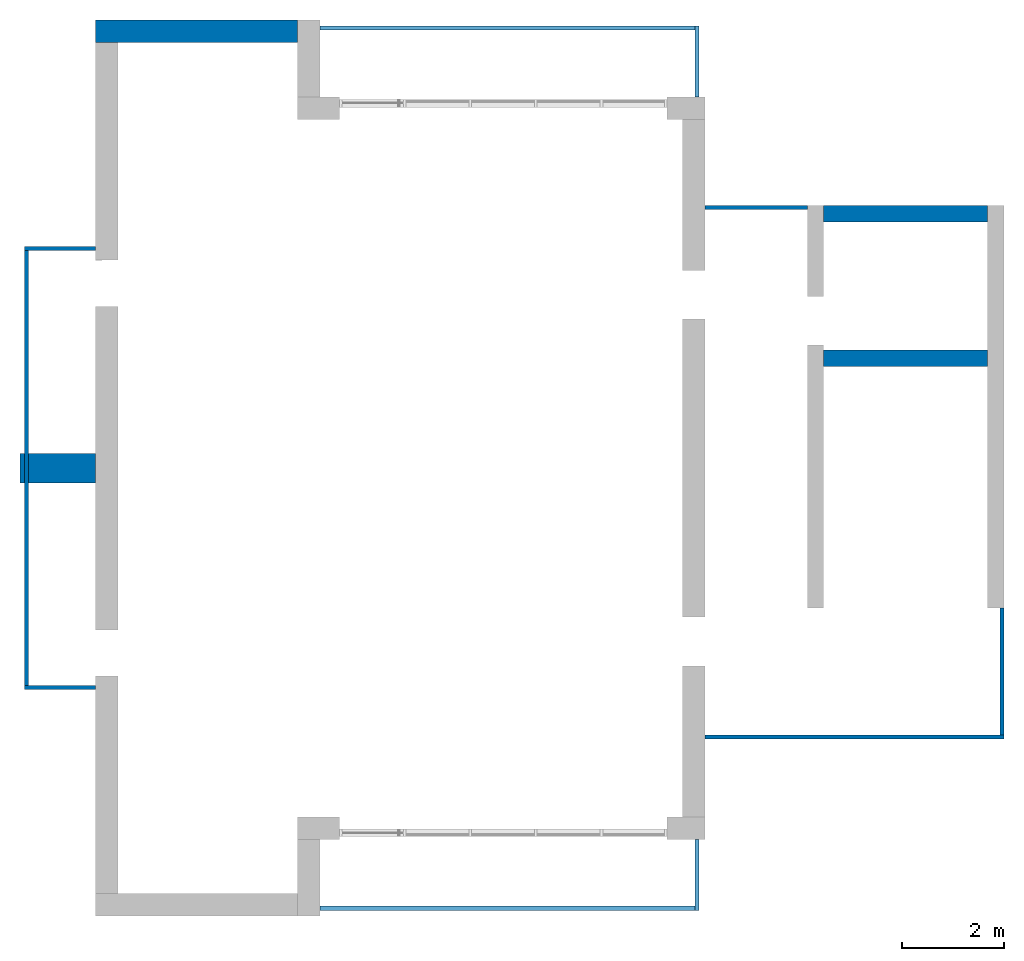
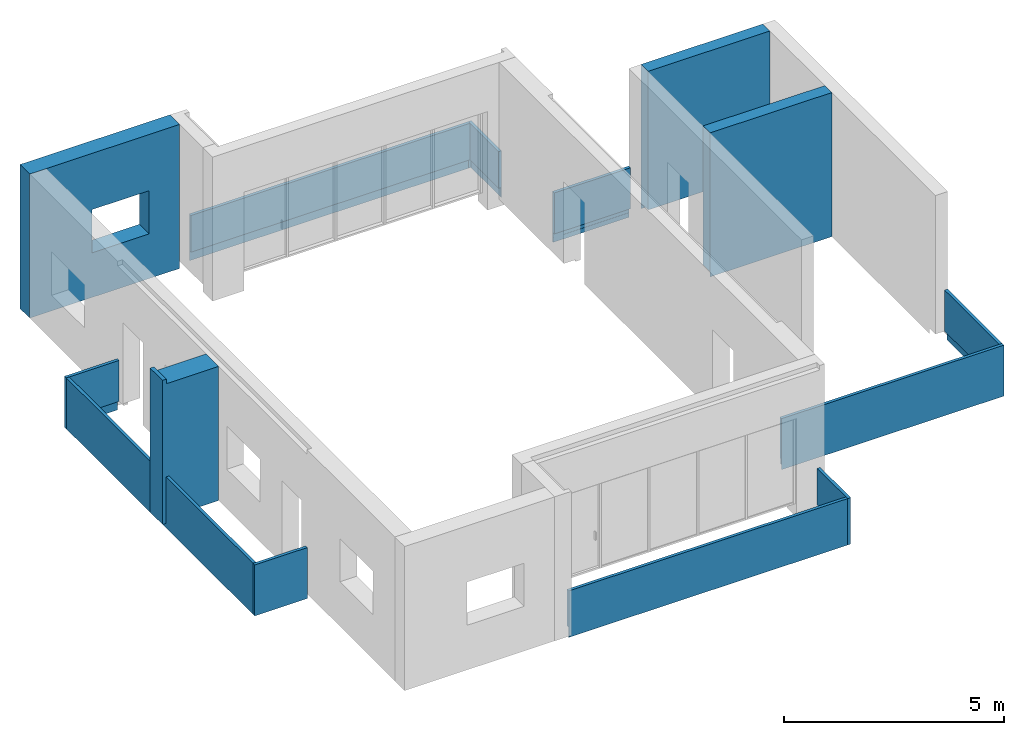
# One storey, part 2 of 4: 14 walls, 1 opening.
"""IFC2X3 building model written with IfcOpenShell, lengths in millimetres."""

from ifc_helpers import new_model, entity, si_unit, converted_unit, derived_unit, direction, frame, frame_2d, origin, place, context, subcontext, project, spatial, polyline, rectangle, extrude, clip, bounded_halfspace, faceted_brep, material, layer, layer_set, layer_usage, type_object, element, save


model = new_model("IFC2X3")

# Units and contexts
model_context = context("Model", 3, precision=0.01, world=origin(), true_north=direction((6.12303176911189e-17, 1.0)))
body_context = subcontext(model_context, "Body", "Model", "MODEL_VIEW")
ifc_project = project(units=[si_unit("LENGTHUNIT", "METRE", prefix="MILLI"), si_unit("AREAUNIT", "SQUARE_METRE"), si_unit("VOLUMEUNIT", "CUBIC_METRE"), converted_unit("PLANEANGLEUNIT", "DEGREE", entity("IfcRatioMeasure", 0.0174532925199433), si_unit("PLANEANGLEUNIT", "RADIAN"), dimensions=[0, 0, 0, 0, 0, 0, 0]), si_unit("MASSUNIT", "GRAM", prefix="KILO"), derived_unit("MASSDENSITYUNIT", [(si_unit("MASSUNIT", "GRAM", prefix="KILO"), 1), (si_unit("LENGTHUNIT", "METRE"), -3)]), si_unit("TIMEUNIT", "SECOND"), si_unit("FREQUENCYUNIT", "HERTZ"), si_unit("THERMODYNAMICTEMPERATUREUNIT", "DEGREE_CELSIUS"), derived_unit("THERMALTRANSMITTANCEUNIT", [(si_unit("MASSUNIT", "GRAM", prefix="KILO"), 1), (si_unit("THERMODYNAMICTEMPERATUREUNIT", "KELVIN"), -1), (si_unit("TIMEUNIT", "SECOND"), -3)]), derived_unit("VOLUMETRICFLOWRATEUNIT", [(si_unit("LENGTHUNIT", "METRE"), 3), (si_unit("TIMEUNIT", "SECOND"), -1)]), si_unit("ELECTRICCURRENTUNIT", "AMPERE"), si_unit("ELECTRICVOLTAGEUNIT", "VOLT"), si_unit("POWERUNIT", "WATT"), si_unit("FORCEUNIT", "NEWTON", prefix="KILO"), si_unit("ILLUMINANCEUNIT", "LUX"), si_unit("LUMINOUSFLUXUNIT", "LUMEN"), si_unit("LUMINOUSINTENSITYUNIT", "CANDELA"), derived_unit("USERDEFINED", [(si_unit("MASSUNIT", "GRAM", prefix="KILO"), -1), (si_unit("LENGTHUNIT", "METRE"), -2), (si_unit("TIMEUNIT", "SECOND"), 3), (si_unit("LUMINOUSFLUXUNIT", "LUMEN"), 1)]), derived_unit("LINEARVELOCITYUNIT", [(si_unit("LENGTHUNIT", "METRE"), 1), (si_unit("TIMEUNIT", "SECOND"), -1)]), si_unit("PRESSUREUNIT", "PASCAL"), derived_unit("USERDEFINED", [(si_unit("LENGTHUNIT", "METRE"), -2), (si_unit("MASSUNIT", "GRAM", prefix="KILO"), 1), (si_unit("TIMEUNIT", "SECOND"), -2)])], contexts=[model_context])

# Site, building, storey
site_placement = place(None, origin())
site = spatial("IfcSite", under=ifc_project, at=site_placement, CompositionType="ELEMENT")
building_placement = place(site_placement, origin())
building = spatial("IfcBuilding", under=site, at=building_placement, CompositionType="ELEMENT")
storey_placement = place(building_placement, frame((0.0, 0.0, 8000.0)))
storey = spatial("IfcBuildingStorey", under=building, at=storey_placement, Name="02 Level", CompositionType="ELEMENT", Elevation=8000.0)

# Wall, opening
ifc_material_1 = material(Name="03")
ifc_layer_1 = layer(ifc_material_1, 10.0)
ifc_material_2 = material()
ifc_layer_2 = layer(ifc_material_2, 120.0)
ifc_material_3 = material()
ifc_layer_3 = layer(ifc_material_3, 300.0)
ifc_layer_4 = layer(ifc_material_1, 10.0)
ifc_layer_set_1 = layer_set([ifc_layer_1, ifc_layer_2, ifc_layer_3, ifc_layer_4], Name="Basic Wall:00_fal+12 cm")
ifc_layer_usage_1 = layer_usage(ifc_layer_set_1, "AXIS2", "POSITIVE", -220.0)
wall_type_1 = type_object("IfcWallType", Name="Basic Wall:00_fal+12 cm", PredefinedType="STANDARD", material=ifc_layer_set_1)
wall_1_placement = place(storey_placement, frame((20983.4900708518, -60301.2395851399, -340.0), z_axis=(0.0, 0.0, 1.0), x_axis=(-1.0, 0.0, 0.0)))
wall_1 = element("IfcWallStandardCase", 1, at=wall_1_placement, inside=storey, type_object=wall_type_1, material=ifc_layer_usage_1, Name="Basic Wall:00_fal+12 cm", ObjectType="Basic Wall:00_fal+12 cm", context=body_context, shape_type="SweptSolid", body=[
    extrude(rectangle(XDim=3940.00000000004, YDim=440.000000000004, at=frame_2d((1970.00000000002, -1.08002495835535e-12), x_axis=(-1.0, 0.0))), origin(), (0.0, 0.0, 1.0), 4000.0),
])
opening_placement = place(wall_1_placement, frame((2300.0, 1304.0, 1240.0), z_axis=(0.0, 0.0, 1.0), x_axis=(-1.0, 0.0, 0.0)))
element("IfcOpeningElement", 2, at=opening_placement, cuts=wall_1, Name="Basic Wall:00_fal+12 cm", ObjectType="Opening", context=body_context, shape_type="SweptSolid", body=[
    extrude(rectangle(XDim=1200.0, YDim=1500.0, at=frame_2d((1.08002495835535e-12, 5.11590769747272e-13), x_axis=(0.0, 1.0))), frame((750.0, 3048.0, 600.0), z_axis=(0.0, -1.0, 0.0), x_axis=(1.0, 0.0, 0.0)), (0.0, 0.0, 1.0), 3048.0),
])

# Walls
ifc_layer_5 = layer(ifc_material_1, 10.0)
ifc_layer_6 = layer(ifc_material_3, 300.0)
ifc_layer_7 = layer(ifc_material_1, 10.0)
ifc_layer_set_2 = layer_set([ifc_layer_5, ifc_layer_6, ifc_layer_7], Name="Basic Wall:00_fal 300 mm")
ifc_layer_usage_2 = layer_usage(ifc_layer_set_2, "AXIS2", "NEGATIVE", 160.0)
wall_type_2 = type_object("IfcWallType", Name="Basic Wall:00_fal 300 mm", PredefinedType="STANDARD", material=ifc_layer_set_2)
wall_2_placement = place(storey_placement, frame((31263.4900708518, -66685.8241905964, -340.0)))
element("IfcWallStandardCase", 3, at=wall_2_placement, inside=storey, type_object=wall_type_2, material=ifc_layer_usage_2, Name="Basic Wall:00_fal 300 mm", ObjectType="Basic Wall:00_fal 300 mm", context=body_context, shape_type="Clipping", body=[
    clip(clip(extrude(rectangle(XDim=3199.99999999998, YDim=319.999999999997, at=frame_2d((1599.99999999999, 1.406874616805e-12), x_axis=(-1.0, 0.0))), origin(), (0.0, 0.0, 1.0), 4000.0), bounded_halfspace(frame((3200.0, -150.0, 150.0), z_axis=(0.0, 0.0, 1.0), x_axis=(0.0, 1.0, 0.0)), True, frame((3200.0, -150.0, 150.0), z_axis=(0.0, 0.0, 1.0), x_axis=(0.0, 1.0, 0.0)), polyline([(0.0, 0.0), (310.0, 0.0), (310.0, 3200.0), (0.0, 3200.0), (0.0, 0.0)]))), bounded_halfspace(frame((0.0, -150.0, 150.0), z_axis=(0.0, -1.0, 0.0), x_axis=(0.0, 0.0, 1.0)), True, frame((0.0, -150.0, 150.0), z_axis=(0.0, -1.0, 0.0), x_axis=(0.0, 0.0, 1.0)), polyline([(0.0, 0.0), (-150.0, 0.0), (-150.0, -3200.0), (0.0, -3200.0), (0.0, 0.0)]))),
])
ifc_layer_usage_3 = layer_usage(ifc_layer_set_2, "AXIS2", "NEGATIVE", 160.0)
wall_3_placement = place(storey_placement, frame((31263.4900708518, -63865.8241905964, -340.0)))
element("IfcWallStandardCase", 4, at=wall_3_placement, inside=storey, type_object=wall_type_2, material=ifc_layer_usage_3, Name="Basic Wall:00_fal 300 mm", ObjectType="Basic Wall:00_fal 300 mm", context=body_context, shape_type="Clipping", body=[
    clip(clip(extrude(rectangle(XDim=3199.99999999998, YDim=319.999999999997, at=frame_2d((1599.99999999999, 0.0), x_axis=(-1.0, 0.0))), origin(), (0.0, 0.0, 1.0), 4000.0), bounded_halfspace(frame((0.0, 150.0, 150.0), z_axis=(0.0, 0.0, 1.0), x_axis=(0.0, 1.0, 0.0)), True, frame((0.0, 150.0, 150.0), z_axis=(0.0, 0.0, 1.0), x_axis=(0.0, 1.0, 0.0)), polyline([(0.0, 0.0), (-310.0, 0.0), (-310.0, -3200.0), (0.0, -3200.0), (0.0, 0.0)]))), bounded_halfspace(frame((3200.0, 150.0, 150.0), z_axis=(0.0, 1.0, 0.0), x_axis=(0.0, 0.0, 1.0)), True, frame((3200.0, 150.0, 150.0), z_axis=(0.0, 1.0, 0.0), x_axis=(0.0, 0.0, 1.0)), polyline([(0.0, 0.0), (-150.0, 0.0), (-150.0, -3200.0), (0.0, -3200.0), (0.0, 0.0)]))),
])
ifc_layer_8 = layer(ifc_material_1, 10.0)
ifc_material_4 = material(Name="06_ APP")
ifc_layer_9 = layer(ifc_material_4, 10.0)
ifc_layer_10 = layer(ifc_material_2, 120.0)
ifc_layer_11 = layer(ifc_material_3, 300.0)
ifc_material_5 = material()
ifc_layer_12 = layer(ifc_material_5, 120.0)
ifc_layer_13 = layer(ifc_material_1, 10.0)
ifc_layer_set_3 = layer_set([ifc_layer_8, ifc_layer_9, ifc_layer_10, ifc_layer_11, ifc_layer_12, ifc_layer_13], Name="Basic Wall:00_fal+2x12 cm")
ifc_layer_usage_4 = layer_usage(ifc_layer_set_3, "AXIS2", "NEGATIVE", 285.0)
wall_type_3 = type_object("IfcWallType", Name="Basic Wall:00_fal+2x12 cm", PredefinedType="STANDARD", material=ifc_layer_set_3)
wall_4_placement = place(storey_placement, frame((17043.4900708518, -68836.2395851399, -340.0), z_axis=(0.0, 0.0, 1.0), x_axis=(-1.0, 0.0, 0.0)))
element("IfcWallStandardCase", 5, at=wall_4_placement, inside=storey, type_object=wall_type_3, material=ifc_layer_usage_4, Name="Basic Wall:00_fal+2x12 cm", ObjectType="Basic Wall:00_fal+2x12 cm", context=body_context, shape_type="Clipping", body=[
    clip(clip(clip(clip(extrude(rectangle(XDim=1474.99999999999, YDim=569.999999999992, at=frame_2d((737.499999999994, -5.6843418860808e-13), x_axis=(-1.0, 0.0))), origin(), (0.0, 0.0, 1.0), 4000.0), bounded_halfspace(frame((1370.0, 285.0, 150.0)), True, frame((1370.0, 285.0, 150.0)), polyline([(0.0, 0.0), (-1370.0, 0.0), (-1370.0, -570.0), (0.0, -570.0), (0.0, 0.0)]))), bounded_halfspace(frame((1370.0, -285.0, 150.0), z_axis=(1.0, 0.0, 0.0), x_axis=(0.0, 0.0, 1.0)), True, frame((1370.0, -285.0, 150.0), z_axis=(1.0, 0.0, 0.0), x_axis=(0.0, 0.0, 1.0)), polyline([(0.0, 0.0), (-150.0, 0.0), (-150.0, -570.0), (0.0, -570.0), (0.0, 0.0)]))), bounded_halfspace(frame((1370.0, -285.0, 3875.0), z_axis=(0.0, 0.0, -1.0), x_axis=(-1.0, 0.0, 0.0)), True, frame((1370.0, -285.0, 3875.0), z_axis=(0.0, 0.0, -1.0), x_axis=(-1.0, 0.0, 0.0)), polyline([(0.0, 0.0), (1370.0, 0.0), (1370.0, 570.0), (0.0, 570.0), (0.0, 0.0)]))), bounded_halfspace(frame((1370.0, 285.0, 3875.0), z_axis=(1.0, 0.0, 0.0), x_axis=(0.0, 0.0, 1.0)), True, frame((1370.0, 285.0, 3875.0), z_axis=(1.0, 0.0, 0.0), x_axis=(0.0, 0.0, 1.0)), polyline([(0.0, 0.0), (125.0, 0.0), (125.0, 570.0), (0.0, 570.0), (0.0, 0.0)]))),
])
ifc_material_6 = material(Name="03")
ifc_layer_14 = layer(ifc_material_6, 15.0)
ifc_material_7 = material(Name="02_C40/55")
ifc_layer_15 = layer(ifc_material_7, 50.0)
ifc_layer_16 = layer(ifc_material_6, 15.0)
ifc_layer_set_4 = layer_set([ifc_layer_14, ifc_layer_15, ifc_layer_16], Name="Basic Wall:00_fal")
ifc_layer_usage_5 = layer_usage(ifc_layer_set_4, "AXIS2", "NEGATIVE", 40.0)
wall_type_4 = type_object("IfcWallType", Name="Basic Wall:00_fal", PredefinedType="STANDARD", material=ifc_layer_set_4)
wall_5_placement = place(storey_placement, frame((28788.4900708518, -76081.2395851399, -465.0), z_axis=(0.0, 0.0, 1.0), x_axis=(0.0, -1.0, 0.0)))
element("IfcWallStandardCase", 6, at=wall_5_placement, inside=storey, type_object=wall_type_4, material=ifc_layer_usage_5, Name="Basic Wall:00_fal", ObjectType="Basic Wall:00_fal", context=body_context, shape_type="Clipping", body=[
    clip(clip(clip(extrude(rectangle(XDim=1384.99999999999, YDim=79.9999999999991, at=frame_2d((692.499999999994, 0.0), x_axis=(-1.0, 0.0))), origin(), (0.0, 0.0, 1.0), 1290.0), bounded_halfspace(frame((1370.0, 25.0, 275.0), z_axis=(0.0, 1.0, 0.0), x_axis=(0.0, 0.0, 1.0)), True, frame((1370.0, 25.0, 275.0), z_axis=(0.0, 1.0, 0.0), x_axis=(0.0, 0.0, 1.0)), polyline([(0.0, 0.0), (-150.0, 0.0), (-275.0, 0.0), (-275.0, -1370.0), (0.0, -1370.0), (0.0, 0.0)]))), bounded_halfspace(frame((1370.0, 25.0, 275.0), z_axis=(1.0, 0.0, 0.0), x_axis=(0.0, 0.0, 1.0)), True, frame((1370.0, 25.0, 275.0), z_axis=(1.0, 0.0, 0.0), x_axis=(0.0, 0.0, 1.0)), polyline([(0.0, 0.0), (0.0, 65.0), (-275.0, 65.0), (-275.0, 0.0), (-150.0, 0.0), (0.0, 0.0)]))), bounded_halfspace(frame((0.0, 25.0, 275.0), z_axis=(0.0, 0.0, 1.0), x_axis=(0.0, -1.0, 0.0)), True, frame((0.0, 25.0, 275.0), z_axis=(0.0, 0.0, 1.0), x_axis=(0.0, -1.0, 0.0)), polyline([(0.0, 0.0), (65.0, 0.0), (65.0, 1305.0), (65.0, 1370.0), (0.0, 1370.0), (0.0, 0.0)]))),
])
ifc_layer_usage_6 = layer_usage(ifc_layer_set_4, "AXIS2", "NEGATIVE", 40.0)
wall_6_placement = place(storey_placement, frame((28748.4900708518, -77426.2395851399, -465.0), z_axis=(0.0, 0.0, 1.0), x_axis=(-1.0, 0.0, 0.0)))
element("IfcWallStandardCase", 7, at=wall_6_placement, inside=storey, type_object=wall_type_4, material=ifc_layer_usage_6, Name="Basic Wall:00_fal", ObjectType="Basic Wall:00_fal", context=body_context, shape_type="Clipping", body=[
    clip(clip(extrude(rectangle(XDim=7325.0, YDim=79.9999999999991, at=frame_2d((3662.5, 0.0), x_axis=(-1.0, 0.0))), origin(), (0.0, 0.0, 1.0), 1290.0), bounded_halfspace(frame((7325.0, -40.0, 275.0)), True, frame((7325.0, -40.0, 275.0)), polyline([(0.0, 0.0), (0.0, 65.0), (-7325.0, 65.0), (-7325.0, 0.0), (0.0, 0.0)]))), bounded_halfspace(frame((0.0, 25.0, 0.0), z_axis=(0.0, 1.0, 0.0), x_axis=(0.0, 0.0, 1.0)), True, frame((0.0, 25.0, 0.0), z_axis=(0.0, 1.0, 0.0), x_axis=(0.0, 0.0, 1.0)), polyline([(0.0, 0.0), (275.0, 0.0), (275.0, 7325.0), (125.0, 7325.0), (0.0, 7325.0), (0.0, 0.0)]))),
])
ifc_layer_usage_7 = layer_usage(ifc_layer_set_4, "AXIS2", "NEGATIVE", 40.0)
wall_7_placement = place(storey_placement, frame((17043.4900708518, -73116.2395851399, -465.0), z_axis=(0.0, 0.0, 1.0), x_axis=(-1.0, 0.0, 0.0)))
element("IfcWallStandardCase", 8, at=wall_7_placement, inside=storey, type_object=wall_type_4, material=ifc_layer_usage_7, Name="Basic Wall:00_fal", ObjectType="Basic Wall:00_fal", context=body_context, shape_type="Clipping", body=[
    clip(clip(clip(extrude(rectangle(XDim=1385.00000000002, YDim=79.9999999999991, at=frame_2d((692.500000000011, 4.9737991503207e-14), x_axis=(-1.0, 0.0))), origin(), (0.0, 0.0, 1.0), 1415.0), bounded_halfspace(frame((1370.0, 25.0, 0.0), z_axis=(1.0, 0.0, 0.0), x_axis=(0.0, 0.0, 1.0)), True, frame((1370.0, 25.0, 0.0), z_axis=(1.0, 0.0, 0.0), x_axis=(0.0, 0.0, 1.0)), polyline([(0.0, 0.0), (125.0, 0.0), (275.0, 0.0), (275.0, 65.0), (0.0, 65.0), (0.0, 0.0)]))), bounded_halfspace(frame((1370.0, 25.0, 0.0), z_axis=(0.0, 1.0, 0.0), x_axis=(0.0, 0.0, 1.0)), True, frame((1370.0, 25.0, 0.0), z_axis=(0.0, 1.0, 0.0), x_axis=(0.0, 0.0, 1.0)), polyline([(0.0, 0.0), (0.0, -1370.0), (125.0, -1370.0), (275.0, -1370.0), (275.0, 0.0), (125.0, 0.0), (0.0, 0.0)]))), bounded_halfspace(frame((1370.0, 25.0, 275.0)), True, frame((1370.0, 25.0, 275.0)), polyline([(0.0, 0.0), (-1370.0, 0.0), (-1370.0, -65.0), (-65.0, -65.0), (0.0, -65.0), (0.0, 0.0)]))),
])
ifc_layer_usage_8 = layer_usage(ifc_layer_set_4, "AXIS2", "NEGATIVE", 40.0)
wall_8_placement = place(storey_placement, frame((15698.4900708517, -73076.2395851399, -465.0), z_axis=(0.0, 0.0, 1.0), x_axis=(0.0, 1.0, 0.0)))
element("IfcWallStandardCase", 9, at=wall_8_placement, inside=storey, type_object=wall_type_4, material=ifc_layer_usage_8, Name="Basic Wall:00_fal", ObjectType="Basic Wall:00_fal", context=body_context, shape_type="Clipping", body=[
    clip(clip(extrude(rectangle(XDim=8489.99999999998, YDim=79.9999999999991, at=frame_2d((4244.99999999999, 3.48165940522449e-13), x_axis=(-1.0, 0.0))), origin(), (0.0, 0.0, 1.0), 1415.0), bounded_halfspace(frame((0.0, 25.0, 0.0), z_axis=(0.0, 1.0, 0.0), x_axis=(0.0, 0.0, 1.0)), True, frame((0.0, 25.0, 0.0), z_axis=(0.0, 1.0, 0.0), x_axis=(0.0, 0.0, 1.0)), polyline([(0.0, 0.0), (125.0, 0.0), (275.0, 0.0), (275.0, 8490.0), (125.0, 8490.0), (0.0, 8490.0), (0.0, 0.0)]))), bounded_halfspace(frame((0.0, 25.0, 275.0), z_axis=(0.0, 0.0, 1.0), x_axis=(0.0, 1.0, 0.0)), True, frame((0.0, 25.0, 275.0), z_axis=(0.0, 0.0, 1.0), x_axis=(0.0, 1.0, 0.0)), polyline([(0.0, 0.0), (-65.0, 0.0), (-65.0, -8490.0), (0.0, -8490.0), (0.0, 0.0)]))),
])
ifc_layer_usage_9 = layer_usage(ifc_layer_set_4, "AXIS2", "POSITIVE", -40.0)
wall_9_placement = place(storey_placement, frame((17043.4900708518, -64546.2395851399, -465.0), z_axis=(0.0, 0.0, 1.0), x_axis=(-1.0, 0.0, 0.0)))
element("IfcWallStandardCase", 10, at=wall_9_placement, inside=storey, type_object=wall_type_4, material=ifc_layer_usage_9, Name="Basic Wall:00_fal", ObjectType="Basic Wall:00_fal", context=body_context, shape_type="Clipping", body=[
    clip(clip(clip(extrude(rectangle(XDim=1385.00000000003, YDim=79.9999999999991, at=frame_2d((692.500000000013, -1.73372427525464e-12), x_axis=(-1.0, 0.0))), origin(), (0.0, 0.0, 1.0), 1415.0), bounded_halfspace(frame((1370.0, -25.0, 275.0), z_axis=(1.0, 0.0, 0.0), x_axis=(0.0, 0.0, 1.0)), True, frame((1370.0, -25.0, 275.0), z_axis=(1.0, 0.0, 0.0), x_axis=(0.0, 0.0, 1.0)), polyline([(0.0, 0.0), (-150.0, 0.0), (-275.0, 0.0), (-275.0, -65.0), (0.0, -65.0), (0.0, 0.0)]))), bounded_halfspace(frame((1370.0, -25.0, 275.0), z_axis=(0.0, -1.0, 0.0), x_axis=(0.0, 0.0, 1.0)), True, frame((1370.0, -25.0, 275.0), z_axis=(0.0, -1.0, 0.0), x_axis=(0.0, 0.0, 1.0)), polyline([(0.0, 0.0), (0.0, 1370.0), (-150.0, 1370.0), (-275.0, 1370.0), (-275.0, 0.0), (-150.0, 0.0), (0.0, 0.0)]))), bounded_halfspace(frame((1370.0, 40.0, 275.0)), True, frame((1370.0, 40.0, 275.0)), polyline([(0.0, 0.0), (-65.0, 0.0), (-1370.0, 0.0), (-1370.0, -65.0), (0.0, -65.0), (0.0, 0.0)]))),
])
wall_10_placement = place(storey_placement, frame((28788.4900708518, -61581.23958514, -465.0), z_axis=(0.0, 0.0, 1.0), x_axis=(0.0, 1.0, 0.0)))
element("IfcWall", 11, at=wall_10_placement, inside=storey, type_object=wall_type_4, Name="Basic Wall:00_fal", ObjectType="Basic Wall:00_fal", context=body_context, shape_type="Brep", body=[
    faceted_brep([(0.0, -40.0, 0.0), (1385.0, -40.0, 0.0), (1385.0, -40.0, 1290.0), (0.0, -40.0, 1290.0), (0.0, 40.0, 1290.0), (1305.0, 40.0, 1290.0), (1385.0, 40.0, 1290.0), (1385.0, 40.0, 0.0), (1370.0, 40.0, 0.0), (1370.0, 40.0, 275.0), (1305.0, 40.0, 275.0), (0.0, 40.0, 275.0), (0.0, -25.0, 0.0), (1370.0, -25.0, 0.0), (0.0, -25.0, 275.0), (1370.0, -25.0, 275.0), (1370.0, -25.0, 125.0)], [[[0, 1, 2, 3]], [[4, 5, 6, 7, 8, 9, 10, 11]], [[1, 0, 12, 13, 8, 7]], [[3, 2, 6, 5, 4]], [[2, 1, 7, 6]], [[0, 3, 4, 11, 14, 12]], [[9, 15, 14, 11, 10]], [[15, 9, 8, 13, 16]], [[15, 16, 13, 12, 14]]]),
])
ifc_layer_usage_10 = layer_usage(ifc_layer_set_4, "AXIS2", "POSITIVE", -40.0)
wall_11_placement = place(storey_placement, frame((28748.4900708518, -60236.23958514, -465.0), z_axis=(0.0, 0.0, 1.0), x_axis=(-1.0, 0.0, 0.0)))
element("IfcWallStandardCase", 12, at=wall_11_placement, inside=storey, type_object=wall_type_4, material=ifc_layer_usage_10, Name="Basic Wall:00_fal", ObjectType="Basic Wall:00_fal", context=body_context, shape_type="Clipping", body=[
    clip(clip(extrude(rectangle(XDim=7325.0, YDim=79.9999999999991, at=frame_2d((3662.5, 4.9382720135327e-13), x_axis=(-1.0, 0.0))), origin(), (0.0, 0.0, 1.0), 1290.0), bounded_halfspace(frame((7325.0, -25.0, 275.0)), True, frame((7325.0, -25.0, 275.0)), polyline([(0.0, 0.0), (0.0, 65.0), (-7325.0, 65.0), (-7325.0, 0.0), (0.0, 0.0)]))), bounded_halfspace(frame((0.0, -25.0, 275.0), z_axis=(0.0, -1.0, 0.0), x_axis=(0.0, 0.0, 1.0)), True, frame((0.0, -25.0, 275.0), z_axis=(0.0, -1.0, 0.0), x_axis=(0.0, 0.0, 1.0)), polyline([(0.0, 0.0), (-275.0, 0.0), (-275.0, -7325.0), (0.0, -7325.0), (0.0, 0.0)]))),
])
ifc_layer_usage_11 = layer_usage(ifc_layer_set_4, "AXIS2", "NEGATIVE", 40.0)
wall_12_placement = place(storey_placement, frame((30943.4900708518, -63745.8241905964, -465.0), z_axis=(0.0, 0.0, 1.0), x_axis=(-1.0, 0.0, 0.0)))
element("IfcWallStandardCase", 13, at=wall_12_placement, inside=storey, type_object=wall_type_4, material=ifc_layer_usage_11, Name="Basic Wall:00_fal", ObjectType="Basic Wall:00_fal", context=body_context, shape_type="Clipping", body=[
    clip(clip(extrude(rectangle(XDim=2000.00000000001, YDim=79.9999999999991, at=frame_2d((1000.00000000001, 0.0), x_axis=(-1.0, 0.0))), origin(), (0.0, 0.0, 1.0), 1415.0), bounded_halfspace(frame((0.0, -30.0, 275.0), z_axis=(0.0, -1.0, 0.0), x_axis=(0.0, 0.0, 1.0)), True, frame((0.0, -30.0, 275.0), z_axis=(0.0, -1.0, 0.0), x_axis=(0.0, 0.0, 1.0)), polyline([(0.0, 0.0), (-150.0, 0.0), (-150.0, -2000.0), (0.0, -2000.0), (0.0, 0.0)]))), bounded_halfspace(frame((2000.0, -25.0, 0.0), z_axis=(0.0, -1.0, 0.0), x_axis=(0.0, 0.0, 1.0)), True, frame((2000.0, -25.0, 0.0), z_axis=(0.0, -1.0, 0.0), x_axis=(0.0, 0.0, 1.0)), polyline([(0.0, 0.0), (125.0, 0.0), (125.0, 2000.0), (0.0, 2000.0), (0.0, 0.0)]))),
])
wall_13_placement = place(storey_placement, frame((34783.4900708518, -74085.8241905963, -465.0), z_axis=(0.0, 0.0, 1.0), x_axis=(-1.0, 0.0, 0.0)))
element("IfcWall", 14, at=wall_13_placement, inside=storey, type_object=wall_type_4, Name="Basic Wall:00_fal", ObjectType="Basic Wall:00_fal", context=body_context, shape_type="Brep", body=[
    faceted_brep([(5840.0, -40.0, 1415.0), (80.0, -40.0, 1415.0), (0.0, -40.0, 1415.0), (0.0, -40.0, 0.0), (10.0, -40.0, 0.0), (10.0, -40.0, 275.0), (80.0, -40.0, 275.0), (5840.0, -40.0, 275.0), (5840.0, -40.0, 465.0), (5840.0, 40.0, 0.0), (0.0, 40.0, 0.0), (0.0, 40.0, 1415.0), (5840.0, 40.0, 1415.0), (5840.0, 30.0, 0.0), (10.0, 30.0, 0.0), (5840.0, -25.0, 275.0), (5840.0, -25.0, 125.0), (5840.0, 30.0, 125.0), (10.0, -25.0, 275.0), (10.0, -25.0, 125.0), (10.0, 30.0, 125.0)], [[[0, 1, 2, 3, 4, 5, 6, 7, 8]], [[9, 10, 11, 12]], [[10, 9, 13, 14, 4, 3]], [[9, 12, 0, 8, 7, 15, 16, 17, 13]], [[2, 1, 0, 12, 11]], [[3, 2, 11, 10]], [[5, 18, 15, 7, 6]], [[19, 18, 5, 4, 14, 20]], [[18, 19, 16, 15]], [[19, 20, 17, 16]], [[20, 14, 13, 17]]]),
])
ifc_layer_usage_12 = layer_usage(ifc_layer_set_4, "AXIS2", "NEGATIVE", 40.0)
wall_14_placement = place(storey_placement, frame((34743.4900708518, -71560.8241905963, -465.0), z_axis=(0.0, 0.0, 1.0), x_axis=(0.0, -1.0, 0.0)))
element("IfcWallStandardCase", 15, at=wall_14_placement, inside=storey, type_object=wall_type_4, material=ifc_layer_usage_12, Name="Basic Wall:00_fal", ObjectType="Basic Wall:00_fal", context=body_context, shape_type="Clipping", body=[
    clip(clip(extrude(rectangle(XDim=2484.99999999999, YDim=79.9999999999991, at=frame_2d((1242.49999999999, 0.0), x_axis=(-1.0, 0.0))), origin(), (0.0, 0.0, 1.0), 1415.0), bounded_halfspace(frame((2485.0, -40.0, 275.0), z_axis=(0.0, 0.0, 1.0), x_axis=(-1.0, 0.0, 0.0)), True, frame((2485.0, -40.0, 275.0), z_axis=(0.0, 0.0, 1.0), x_axis=(-1.0, 0.0, 0.0)), polyline([(0.0, 0.0), (0.0, -70.0), (2485.0, -70.0), (2485.0, 0.0), (0.0, 0.0)]))), bounded_halfspace(frame((2485.0, 30.0, 275.0), z_axis=(0.0, 1.0, 0.0), x_axis=(0.0, 0.0, 1.0)), True, frame((2485.0, 30.0, 275.0), z_axis=(0.0, 1.0, 0.0), x_axis=(0.0, 0.0, 1.0)), polyline([(0.0, 0.0), (-275.0, 0.0), (-275.0, -2485.0), (-150.0, -2485.0), (0.0, -2485.0), (0.0, 0.0)]))),
])

save(model, "model.ifc")
